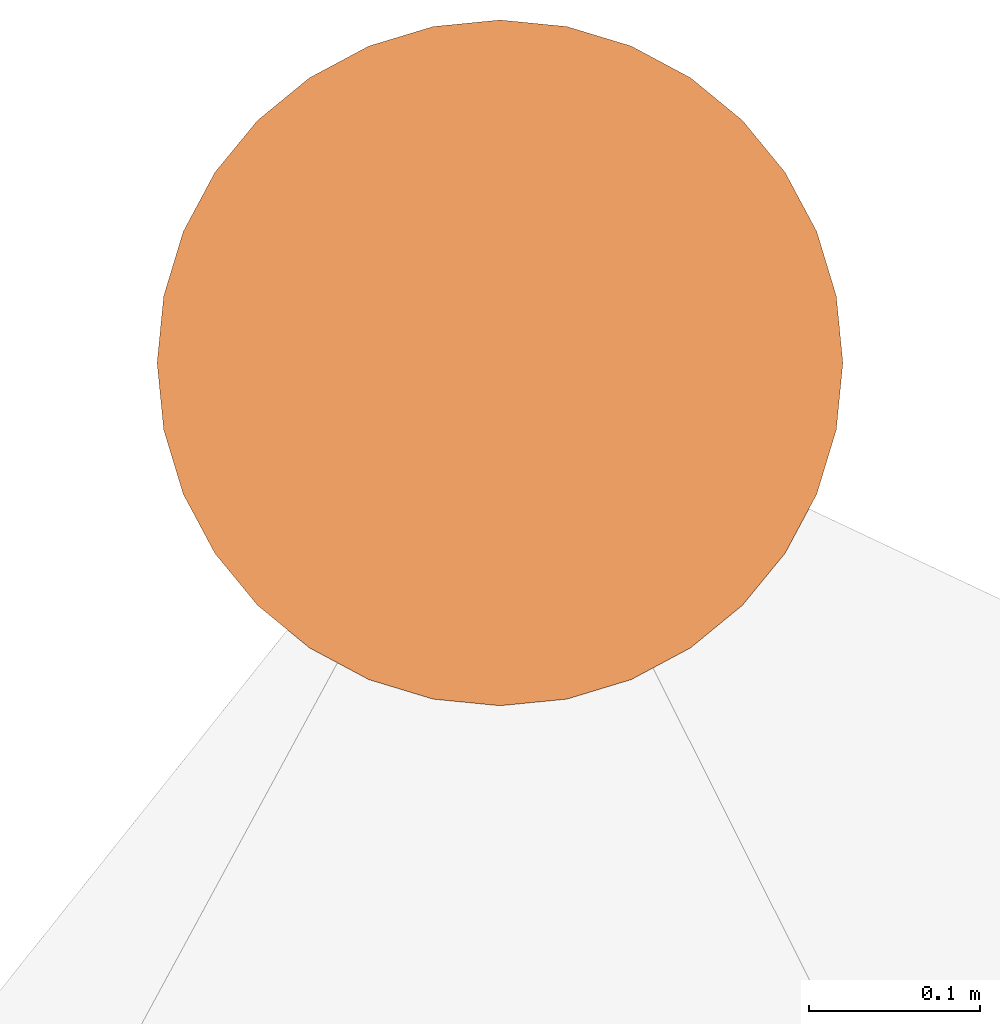
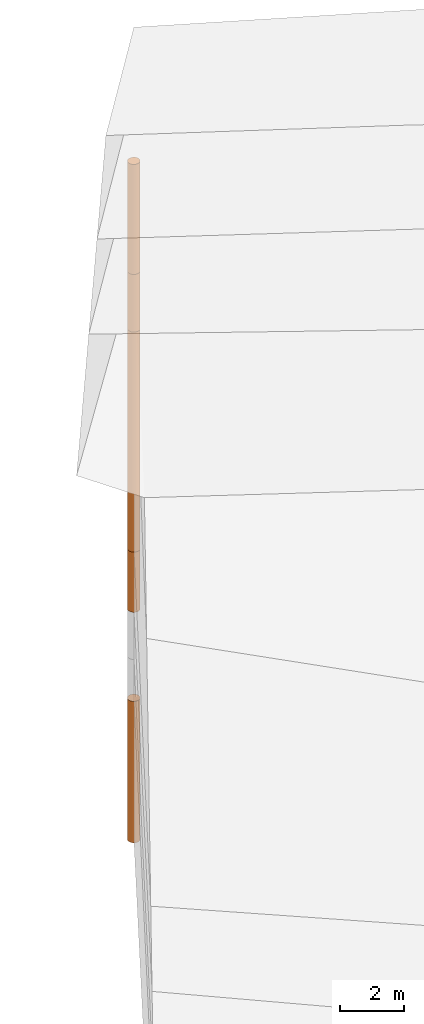
# One storey, part 18 of 24: 5 geographic elements.
"""IFC4 building model written with IfcOpenShell, lengths in metres."""

from ifc_helpers import new_model, entity, si_unit, converted_unit, frame, origin_with_axes, origin_2d_with_axis, place, context, subcontext, project, spatial, polygons, element, save


model = new_model("IFC4")

# Units and contexts
model_context = context("Model", 3, precision=1e-05, world=origin_with_axes())
plan_context = context("Plan", 2, precision=1e-05, world=origin_2d_with_axis())
body_context = subcontext(model_context, "Body", "Model", "MODEL_VIEW")
ifc_project = project(units=[converted_unit("PLANEANGLEUNIT", "degree", entity("IfcReal", 0.0174532925199433), si_unit("PLANEANGLEUNIT", "RADIAN"), dimensions=[0, 0, 0, 0, 0, 0, 0]), si_unit("AREAUNIT", "SQUARE_METRE"), si_unit("VOLUMEUNIT", "CUBIC_METRE"), si_unit("LENGTHUNIT", "METRE")], contexts=[model_context, plan_context])

# Site, building, storey
site_placement = place(None, origin_with_axes())
site = spatial("IfcSite", under=ifc_project, at=site_placement)
building_placement = place(site_placement, origin_with_axes())
building = spatial("IfcBuilding", under=site, at=building_placement, Name="Building")
storey_placement = place(building_placement, origin_with_axes())
storey = spatial("IfcBuildingStorey", under=building, at=storey_placement, Name="Storey")

# Geographic elements
geographic_element_1_placement = place(storey_placement, frame((19.3999996185303, 90.9000015258789, -2.14999771118164), z_axis=(0.0, 0.0, 1.0), x_axis=(1.0, 0.0, 0.0)))
element("IfcGeographicElement", 1, at=geographic_element_1_placement, inside=storey, PredefinedType="NOTDEFINED", context=body_context, shape_type="Tessellation", body=[
    polygons([(0.0, 0.0, -1.14999973773956), (0.0390180610120296, 0.196157038211823, -1.14999973773956), (0.0, 0.199999988079071, -1.14999973773956), (0.0, 0.0, 1.14999973773956), (0.0, 0.199999988079071, 1.14999973773956), (0.0390180610120296, 0.196157038211823, 1.14999973773956), (0.0765366926789284, 0.18477588891983, -1.14999973773956), (0.0765366926789284, 0.18477588891983, 1.14999973773956), (0.111114047467709, 0.166293919086456, -1.14999973773956), (0.111114047467709, 0.166293919086456, 1.14999973773956), (0.141421362757683, 0.141421362757683, -1.14999973773956), (0.141421362757683, 0.141421362757683, 1.14999973773956), (0.166293919086456, 0.111114047467709, -1.14999973773956), (0.166293919086456, 0.111114047467709, 1.14999973773956), (0.18477588891983, 0.0765366926789284, -1.14999973773956), (0.18477588891983, 0.0765366926789284, 1.14999973773956), (0.196157038211823, 0.0390180610120296, -1.14999973773956), (0.196157038211823, 0.0390180610120296, 1.14999973773956), (0.199999988079071, 0.0, -1.14999973773956), (0.199999988079071, 0.0, 1.14999973773956), (0.196157038211823, -0.0390180610120296, -1.14999973773956), (0.196157038211823, -0.0390180610120296, 1.14999973773956), (0.18477588891983, -0.0765366926789284, -1.14999973773956), (0.18477588891983, -0.0765366926789284, 1.14999973773956), (0.166293919086456, -0.111114047467709, -1.14999973773956), (0.166293919086456, -0.111114047467709, 1.14999973773956), (0.141421362757683, -0.141421362757683, -1.14999973773956), (0.141421362757683, -0.141421362757683, 1.14999973773956), (0.111114047467709, -0.166293919086456, -1.14999973773956), (0.111114047467709, -0.166293919086456, 1.14999973773956), (0.0765366926789284, -0.18477588891983, -1.14999973773956), (0.0765366926789284, -0.18477588891983, 1.14999973773956), (0.0390180610120296, -0.196157038211823, -1.14999973773956), (0.0390180610120296, -0.196157038211823, 1.14999973773956), (0.0, -0.199999988079071, -1.14999973773956), (0.0, -0.199999988079071, 1.14999973773956), (-0.0390180610120296, -0.196157038211823, -1.14999973773956), (-0.0390180610120296, -0.196157038211823, 1.14999973773956), (-0.0765366926789284, -0.18477588891983, -1.14999973773956), (-0.0765366926789284, -0.18477588891983, 1.14999973773956), (-0.111114047467709, -0.166293919086456, -1.14999973773956), (-0.111114047467709, -0.166293919086456, 1.14999973773956), (-0.141421362757683, -0.141421362757683, -1.14999973773956), (-0.141421362757683, -0.141421362757683, 1.14999973773956), (-0.166293919086456, -0.111114047467709, -1.14999973773956), (-0.166293919086456, -0.111114047467709, 1.14999973773956), (-0.18477588891983, -0.0765366926789284, -1.14999973773956), (-0.18477588891983, -0.0765366926789284, 1.14999973773956), (-0.196157038211823, -0.0390180610120296, -1.14999973773956), (-0.196157038211823, -0.0390180610120296, 1.14999973773956), (-0.199999988079071, 0.0, -1.14999973773956), (-0.199999988079071, 0.0, 1.14999973773956), (-0.196157038211823, 0.0390180610120296, -1.14999973773956), (-0.196157038211823, 0.0390180610120296, 1.14999973773956), (-0.18477588891983, 0.0765366926789284, -1.14999973773956), (-0.18477588891983, 0.0765366926789284, 1.14999973773956), (-0.166293919086456, 0.111114047467709, -1.14999973773956), (-0.166293919086456, 0.111114047467709, 1.14999973773956), (-0.141421362757683, 0.141421362757683, -1.14999973773956), (-0.141421362757683, 0.141421362757683, 1.14999973773956), (-0.111114047467709, 0.166293919086456, -1.14999973773956), (-0.111114047467709, 0.166293919086456, 1.14999973773956), (-0.0765366926789284, 0.18477588891983, -1.14999973773956), (-0.0765366926789284, 0.18477588891983, 1.14999973773956), (-0.0390180610120296, 0.196157038211823, -1.14999973773956), (-0.0390180610120296, 0.196157038211823, 1.14999973773956)], [[[3, 2, 1]], [[6, 5, 4]], [[28, 30, 29, 27]], [[2, 7, 1]], [[8, 6, 4]], [[42, 44, 43, 41]], [[7, 9, 1]], [[10, 8, 4]], [[10, 12, 11, 9]], [[9, 11, 1]], [[12, 10, 4]], [[11, 13, 1]], [[12, 4, 14]], [[46, 48, 47, 45]], [[1, 13, 15]], [[14, 4, 16]], [[34, 36, 35, 33]], [[1, 15, 17]], [[16, 4, 18]], [[54, 56, 55, 53]], [[1, 17, 19]], [[4, 20, 18]], [[16, 18, 17, 15]], [[1, 19, 21]], [[4, 22, 20]], [[18, 20, 19, 17]], [[1, 21, 23]], [[22, 4, 24]], [[20, 22, 21, 19]], [[1, 23, 25]], [[24, 4, 26]], [[58, 60, 59, 57]], [[1, 25, 27]], [[26, 4, 28]], [[24, 26, 25, 23]], [[1, 27, 29]], [[28, 4, 30]], [[26, 28, 27, 25]], [[1, 29, 31]], [[4, 32, 30]], [[5, 6, 2, 3]], [[1, 31, 33]], [[4, 34, 32]], [[64, 66, 65, 63]], [[1, 33, 35]], [[4, 36, 34]], [[8, 10, 9, 7]], [[1, 35, 37]], [[4, 38, 36]], [[32, 34, 33, 31]], [[1, 37, 39]], [[4, 40, 38]], [[36, 38, 37, 35]], [[1, 39, 41]], [[4, 42, 40]], [[38, 40, 39, 37]], [[43, 1, 41]], [[4, 44, 42]], [[40, 42, 41, 39]], [[45, 1, 43]], [[4, 46, 44]], [[6, 8, 7, 2]], [[47, 1, 45]], [[4, 48, 46]], [[66, 5, 3, 65]], [[49, 1, 47]], [[4, 50, 48]], [[50, 52, 51, 49]], [[49, 51, 1]], [[52, 50, 4]], [[14, 16, 15, 13]], [[51, 53, 1]], [[54, 52, 4]], [[48, 50, 49, 47]], [[55, 1, 53]], [[4, 56, 54]], [[52, 54, 53, 51]], [[57, 1, 55]], [[4, 58, 56]], [[22, 24, 23, 21]], [[59, 1, 57]], [[60, 58, 4]], [[56, 58, 57, 55]], [[59, 61, 1]], [[62, 60, 4]], [[30, 32, 31, 29]], [[61, 63, 1]], [[64, 62, 4]], [[60, 62, 61, 59]], [[63, 65, 1]], [[66, 64, 4]], [[62, 64, 63, 61]], [[65, 3, 1]], [[5, 66, 4]], [[44, 46, 45, 43]], [[12, 14, 13, 11]]]),
])
geographic_element_2_placement = place(storey_placement, frame((19.3999996185303, 90.9000015258789, 3.20000219345093), z_axis=(0.0, 0.0, 1.0), x_axis=(1.0, 0.0, 0.0)))
element("IfcGeographicElement", 2, at=geographic_element_2_placement, inside=storey, PredefinedType="NOTDEFINED", context=body_context, shape_type="Tessellation", body=[
    polygons([(0.0, 0.0, -4.19999933242798), (0.0390180610120296, 0.196157038211823, -4.19999933242798), (0.0, 0.199999988079071, -4.19999933242798), (0.0, 0.0, 4.19999933242798), (0.0, 0.199999988079071, 4.19999933242798), (0.0390180610120296, 0.196157038211823, 4.19999933242798), (0.0765366926789284, 0.18477588891983, -4.19999933242798), (0.0765366926789284, 0.18477588891983, 4.19999933242798), (0.111114047467709, 0.166293919086456, -4.19999933242798), (0.111114047467709, 0.166293919086456, 4.19999933242798), (0.141421362757683, 0.141421362757683, -4.19999933242798), (0.141421362757683, 0.141421362757683, 4.19999933242798), (0.166293919086456, 0.111114047467709, -4.19999933242798), (0.166293919086456, 0.111114047467709, 4.19999933242798), (0.18477588891983, 0.0765366926789284, -4.19999933242798), (0.18477588891983, 0.0765366926789284, 4.19999933242798), (0.196157038211823, 0.0390180610120296, -4.19999933242798), (0.196157038211823, 0.0390180610120296, 4.19999933242798), (0.199999988079071, 0.0, -4.19999933242798), (0.199999988079071, 0.0, 4.19999933242798), (0.196157038211823, -0.0390180610120296, -4.19999933242798), (0.196157038211823, -0.0390180610120296, 4.19999933242798), (0.18477588891983, -0.0765366926789284, -4.19999933242798), (0.18477588891983, -0.0765366926789284, 4.19999933242798), (0.166293919086456, -0.111114047467709, -4.19999933242798), (0.166293919086456, -0.111114047467709, 4.19999933242798), (0.141421362757683, -0.141421362757683, -4.19999933242798), (0.141421362757683, -0.141421362757683, 4.19999933242798), (0.111114047467709, -0.166293919086456, -4.19999933242798), (0.111114047467709, -0.166293919086456, 4.19999933242798), (0.0765366926789284, -0.18477588891983, -4.19999933242798), (0.0765366926789284, -0.18477588891983, 4.19999933242798), (0.0390180610120296, -0.196157038211823, -4.19999933242798), (0.0390180610120296, -0.196157038211823, 4.19999933242798), (0.0, -0.199999988079071, -4.19999933242798), (0.0, -0.199999988079071, 4.19999933242798), (-0.0390180610120296, -0.196157038211823, -4.19999933242798), (-0.0390180610120296, -0.196157038211823, 4.19999933242798), (-0.0765366926789284, -0.18477588891983, -4.19999933242798), (-0.0765366926789284, -0.18477588891983, 4.19999933242798), (-0.111114047467709, -0.166293919086456, -4.19999933242798), (-0.111114047467709, -0.166293919086456, 4.19999933242798), (-0.141421362757683, -0.141421362757683, -4.19999933242798), (-0.141421362757683, -0.141421362757683, 4.19999933242798), (-0.166293919086456, -0.111114047467709, -4.19999933242798), (-0.166293919086456, -0.111114047467709, 4.19999933242798), (-0.18477588891983, -0.0765366926789284, -4.19999933242798), (-0.18477588891983, -0.0765366926789284, 4.19999933242798), (-0.196157038211823, -0.0390180610120296, -4.19999933242798), (-0.196157038211823, -0.0390180610120296, 4.19999933242798), (-0.199999988079071, 0.0, -4.19999933242798), (-0.199999988079071, 0.0, 4.19999933242798), (-0.196157038211823, 0.0390180610120296, -4.19999933242798), (-0.196157038211823, 0.0390180610120296, 4.19999933242798), (-0.18477588891983, 0.0765366926789284, -4.19999933242798), (-0.18477588891983, 0.0765366926789284, 4.19999933242798), (-0.166293919086456, 0.111114047467709, -4.19999933242798), (-0.166293919086456, 0.111114047467709, 4.19999933242798), (-0.141421362757683, 0.141421362757683, -4.19999933242798), (-0.141421362757683, 0.141421362757683, 4.19999933242798), (-0.111114047467709, 0.166293919086456, -4.19999933242798), (-0.111114047467709, 0.166293919086456, 4.19999933242798), (-0.0765366926789284, 0.18477588891983, -4.19999933242798), (-0.0765366926789284, 0.18477588891983, 4.19999933242798), (-0.0390180610120296, 0.196157038211823, -4.19999933242798), (-0.0390180610120296, 0.196157038211823, 4.19999933242798)], [[[3, 2, 1]], [[6, 5, 4]], [[66, 5, 3, 65]], [[2, 7, 1]], [[8, 6, 4]], [[64, 66, 65, 63]], [[7, 9, 1]], [[10, 8, 4]], [[42, 44, 43, 41]], [[9, 11, 1]], [[12, 10, 4]], [[12, 14, 13, 11]], [[1, 11, 13]], [[12, 4, 14]], [[41, 39, 40, 42]], [[1, 13, 15]], [[14, 4, 16]], [[26, 28, 27, 25]], [[1, 15, 17]], [[16, 4, 18]], [[5, 6, 2, 3]], [[1, 17, 19]], [[4, 20, 18]], [[34, 36, 35, 33]], [[1, 19, 21]], [[20, 4, 22]], [[18, 20, 19, 17]], [[1, 21, 23]], [[22, 4, 24]], [[6, 8, 7, 2]], [[1, 23, 25]], [[4, 26, 24]], [[60, 62, 61, 59]], [[1, 25, 27]], [[4, 28, 26]], [[28, 30, 29, 27]], [[1, 27, 29]], [[28, 4, 30]], [[9, 7, 8, 10]], [[1, 29, 31]], [[4, 32, 30]], [[58, 60, 59, 57]], [[1, 31, 33]], [[4, 34, 32]], [[44, 46, 45, 43]], [[1, 33, 35]], [[4, 36, 34]], [[36, 38, 37, 35]], [[1, 35, 37]], [[4, 38, 36]], [[54, 56, 55, 53]], [[1, 37, 39]], [[4, 40, 38]], [[32, 34, 33, 31]], [[1, 39, 41]], [[4, 42, 40]], [[24, 26, 25, 23]], [[43, 1, 41]], [[4, 44, 42]], [[43, 45, 1]], [[4, 46, 44]], [[56, 58, 57, 55]], [[45, 47, 1]], [[4, 48, 46]], [[63, 61, 62, 64]], [[49, 1, 47]], [[4, 50, 48]], [[38, 40, 39, 37]], [[51, 1, 49]], [[52, 50, 4]], [[48, 50, 49, 47]], [[51, 53, 1]], [[4, 54, 52]], [[50, 52, 51, 49]], [[55, 1, 53]], [[4, 56, 54]], [[52, 54, 53, 51]], [[57, 1, 55]], [[58, 56, 4]], [[46, 48, 47, 45]], [[59, 1, 57]], [[60, 58, 4]], [[10, 12, 11, 9]], [[59, 61, 1]], [[62, 60, 4]], [[14, 16, 15, 13]], [[61, 63, 1]], [[64, 62, 4]], [[31, 29, 30, 32]], [[63, 65, 1]], [[66, 64, 4]], [[20, 22, 21, 19]], [[65, 3, 1]], [[5, 66, 4]], [[22, 24, 23, 21]], [[16, 18, 17, 15]]]),
])
geographic_element_3_placement = place(storey_placement, frame((19.3999996185303, 90.9000015258789, 8.50000190734863), z_axis=(0.0, 0.0, 1.0), x_axis=(1.0, 0.0, 0.0)))
element("IfcGeographicElement", 3, at=geographic_element_3_placement, inside=storey, PredefinedType="NOTDEFINED", context=body_context, shape_type="Tessellation", body=[
    polygons([(0.0, 0.0, -1.09999990463257), (0.0390180610120296, 0.196157038211823, -1.09999990463257), (0.0, 0.199999988079071, -1.09999990463257), (0.0, 0.0, 1.09999990463257), (0.0, 0.199999988079071, 1.09999990463257), (0.0390180610120296, 0.196157038211823, 1.09999990463257), (0.0765366926789284, 0.18477588891983, -1.09999990463257), (0.0765366926789284, 0.18477588891983, 1.09999990463257), (0.111114047467709, 0.166293919086456, -1.09999990463257), (0.111114047467709, 0.166293919086456, 1.09999990463257), (0.141421362757683, 0.141421362757683, -1.09999990463257), (0.141421362757683, 0.141421362757683, 1.09999990463257), (0.166293919086456, 0.111114047467709, -1.09999990463257), (0.166293919086456, 0.111114047467709, 1.09999990463257), (0.18477588891983, 0.0765366926789284, -1.09999990463257), (0.18477588891983, 0.0765366926789284, 1.09999990463257), (0.196157038211823, 0.0390180610120296, -1.09999990463257), (0.196157038211823, 0.0390180610120296, 1.09999990463257), (0.199999988079071, 0.0, -1.09999990463257), (0.199999988079071, 0.0, 1.09999990463257), (0.196157038211823, -0.0390180610120296, -1.09999990463257), (0.196157038211823, -0.0390180610120296, 1.09999990463257), (0.18477588891983, -0.0765366926789284, -1.09999990463257), (0.18477588891983, -0.0765366926789284, 1.09999990463257), (0.166293919086456, -0.111114047467709, -1.09999990463257), (0.166293919086456, -0.111114047467709, 1.09999990463257), (0.141421362757683, -0.141421362757683, -1.09999990463257), (0.141421362757683, -0.141421362757683, 1.09999990463257), (0.111114047467709, -0.166293919086456, -1.09999990463257), (0.111114047467709, -0.166293919086456, 1.09999990463257), (0.0765366926789284, -0.18477588891983, -1.09999990463257), (0.0765366926789284, -0.18477588891983, 1.09999990463257), (0.0390180610120296, -0.196157038211823, -1.09999990463257), (0.0390180610120296, -0.196157038211823, 1.09999990463257), (0.0, -0.199999988079071, -1.09999990463257), (0.0, -0.199999988079071, 1.09999990463257), (-0.0390180610120296, -0.196157038211823, -1.09999990463257), (-0.0390180610120296, -0.196157038211823, 1.09999990463257), (-0.0765366926789284, -0.18477588891983, -1.09999990463257), (-0.0765366926789284, -0.18477588891983, 1.09999990463257), (-0.111114047467709, -0.166293919086456, -1.09999990463257), (-0.111114047467709, -0.166293919086456, 1.09999990463257), (-0.141421362757683, -0.141421362757683, -1.09999990463257), (-0.141421362757683, -0.141421362757683, 1.09999990463257), (-0.166293919086456, -0.111114047467709, -1.09999990463257), (-0.166293919086456, -0.111114047467709, 1.09999990463257), (-0.18477588891983, -0.0765366926789284, -1.09999990463257), (-0.18477588891983, -0.0765366926789284, 1.09999990463257), (-0.196157038211823, -0.0390180610120296, -1.09999990463257), (-0.196157038211823, -0.0390180610120296, 1.09999990463257), (-0.199999988079071, 0.0, -1.09999990463257), (-0.199999988079071, 0.0, 1.09999990463257), (-0.196157038211823, 0.0390180610120296, -1.09999990463257), (-0.196157038211823, 0.0390180610120296, 1.09999990463257), (-0.18477588891983, 0.0765366926789284, -1.09999990463257), (-0.18477588891983, 0.0765366926789284, 1.09999990463257), (-0.166293919086456, 0.111114047467709, -1.09999990463257), (-0.166293919086456, 0.111114047467709, 1.09999990463257), (-0.141421362757683, 0.141421362757683, -1.09999990463257), (-0.141421362757683, 0.141421362757683, 1.09999990463257), (-0.111114047467709, 0.166293919086456, -1.09999990463257), (-0.111114047467709, 0.166293919086456, 1.09999990463257), (-0.0765366926789284, 0.18477588891983, -1.09999990463257), (-0.0765366926789284, 0.18477588891983, 1.09999990463257), (-0.0390180610120296, 0.196157038211823, -1.09999990463257), (-0.0390180610120296, 0.196157038211823, 1.09999990463257)], [[[3, 2, 1]], [[6, 5, 4]], [[28, 30, 29, 27]], [[2, 7, 1]], [[8, 6, 4]], [[42, 44, 43, 41]], [[7, 9, 1]], [[10, 8, 4]], [[10, 12, 11, 9]], [[9, 11, 1]], [[12, 10, 4]], [[11, 13, 1]], [[12, 4, 14]], [[46, 48, 47, 45]], [[1, 13, 15]], [[4, 16, 14]], [[34, 36, 35, 33]], [[1, 15, 17]], [[4, 18, 16]], [[54, 56, 55, 53]], [[1, 17, 19]], [[4, 20, 18]], [[16, 18, 17, 15]], [[1, 19, 21]], [[20, 4, 22]], [[18, 20, 19, 17]], [[1, 21, 23]], [[22, 4, 24]], [[20, 22, 21, 19]], [[1, 23, 25]], [[4, 26, 24]], [[58, 60, 59, 57]], [[1, 25, 27]], [[26, 4, 28]], [[24, 26, 25, 23]], [[1, 27, 29]], [[28, 4, 30]], [[26, 28, 27, 25]], [[1, 29, 31]], [[4, 32, 30]], [[5, 6, 2, 3]], [[1, 31, 33]], [[4, 34, 32]], [[64, 66, 65, 63]], [[1, 33, 35]], [[4, 36, 34]], [[8, 10, 9, 7]], [[1, 35, 37]], [[4, 38, 36]], [[32, 34, 33, 31]], [[1, 37, 39]], [[4, 40, 38]], [[36, 38, 37, 35]], [[1, 39, 41]], [[4, 42, 40]], [[38, 40, 39, 37]], [[43, 1, 41]], [[4, 44, 42]], [[40, 42, 41, 39]], [[45, 1, 43]], [[4, 46, 44]], [[6, 8, 7, 2]], [[45, 47, 1]], [[48, 46, 4]], [[66, 5, 3, 65]], [[49, 1, 47]], [[50, 48, 4]], [[50, 52, 51, 49]], [[51, 1, 49]], [[52, 50, 4]], [[14, 16, 15, 13]], [[51, 53, 1]], [[4, 54, 52]], [[48, 50, 49, 47]], [[53, 55, 1]], [[4, 56, 54]], [[52, 54, 53, 51]], [[55, 57, 1]], [[58, 56, 4]], [[22, 24, 23, 21]], [[59, 1, 57]], [[60, 58, 4]], [[56, 58, 57, 55]], [[59, 61, 1]], [[62, 60, 4]], [[30, 32, 31, 29]], [[61, 63, 1]], [[64, 62, 4]], [[60, 62, 61, 59]], [[63, 65, 1]], [[66, 64, 4]], [[62, 64, 63, 61]], [[65, 3, 1]], [[5, 66, 4]], [[44, 46, 45, 43]], [[12, 14, 13, 11]]]),
])
geographic_element_4_placement = place(storey_placement, frame((19.3999996185303, 90.9000015258789, 11.7000017166138), z_axis=(0.0, 0.0, 1.0), x_axis=(1.0, 0.0, 0.0)))
element("IfcGeographicElement", 4, at=geographic_element_4_placement, inside=storey, PredefinedType="NOTDEFINED", context=body_context, shape_type="Tessellation", body=[
    polygons([(0.0, 0.0, -2.09999966621399), (0.0390180610120296, 0.196157038211823, -2.09999966621399), (0.0, 0.199999988079071, -2.09999966621399), (0.0, 0.0, 2.09999966621399), (0.0, 0.199999988079071, 2.09999966621399), (0.0390180610120296, 0.196157038211823, 2.09999966621399), (0.0765366926789284, 0.18477588891983, -2.09999966621399), (0.0765366926789284, 0.18477588891983, 2.09999966621399), (0.111114047467709, 0.166293919086456, -2.09999966621399), (0.111114047467709, 0.166293919086456, 2.09999966621399), (0.141421362757683, 0.141421362757683, -2.09999966621399), (0.141421362757683, 0.141421362757683, 2.09999966621399), (0.166293919086456, 0.111114047467709, -2.09999966621399), (0.166293919086456, 0.111114047467709, 2.09999966621399), (0.18477588891983, 0.0765366926789284, -2.09999966621399), (0.18477588891983, 0.0765366926789284, 2.09999966621399), (0.196157038211823, 0.0390180610120296, -2.09999966621399), (0.196157038211823, 0.0390180610120296, 2.09999966621399), (0.199999988079071, 0.0, -2.09999966621399), (0.199999988079071, 0.0, 2.09999966621399), (0.196157038211823, -0.0390180610120296, -2.09999966621399), (0.196157038211823, -0.0390180610120296, 2.09999966621399), (0.18477588891983, -0.0765366926789284, -2.09999966621399), (0.18477588891983, -0.0765366926789284, 2.09999966621399), (0.166293919086456, -0.111114047467709, -2.09999966621399), (0.166293919086456, -0.111114047467709, 2.09999966621399), (0.141421362757683, -0.141421362757683, -2.09999966621399), (0.141421362757683, -0.141421362757683, 2.09999966621399), (0.111114047467709, -0.166293919086456, -2.09999966621399), (0.111114047467709, -0.166293919086456, 2.09999966621399), (0.0765366926789284, -0.18477588891983, -2.09999966621399), (0.0765366926789284, -0.18477588891983, 2.09999966621399), (0.0390180610120296, -0.196157038211823, -2.09999966621399), (0.0390180610120296, -0.196157038211823, 2.09999966621399), (0.0, -0.199999988079071, -2.09999966621399), (0.0, -0.199999988079071, 2.09999966621399), (-0.0390180610120296, -0.196157038211823, -2.09999966621399), (-0.0390180610120296, -0.196157038211823, 2.09999966621399), (-0.0765366926789284, -0.18477588891983, -2.09999966621399), (-0.0765366926789284, -0.18477588891983, 2.09999966621399), (-0.111114047467709, -0.166293919086456, -2.09999966621399), (-0.111114047467709, -0.166293919086456, 2.09999966621399), (-0.141421362757683, -0.141421362757683, -2.09999966621399), (-0.141421362757683, -0.141421362757683, 2.09999966621399), (-0.166293919086456, -0.111114047467709, -2.09999966621399), (-0.166293919086456, -0.111114047467709, 2.09999966621399), (-0.18477588891983, -0.0765366926789284, -2.09999966621399), (-0.18477588891983, -0.0765366926789284, 2.09999966621399), (-0.196157038211823, -0.0390180610120296, -2.09999966621399), (-0.196157038211823, -0.0390180610120296, 2.09999966621399), (-0.199999988079071, 0.0, -2.09999966621399), (-0.199999988079071, 0.0, 2.09999966621399), (-0.196157038211823, 0.0390180610120296, -2.09999966621399), (-0.196157038211823, 0.0390180610120296, 2.09999966621399), (-0.18477588891983, 0.0765366926789284, -2.09999966621399), (-0.18477588891983, 0.0765366926789284, 2.09999966621399), (-0.166293919086456, 0.111114047467709, -2.09999966621399), (-0.166293919086456, 0.111114047467709, 2.09999966621399), (-0.141421362757683, 0.141421362757683, -2.09999966621399), (-0.141421362757683, 0.141421362757683, 2.09999966621399), (-0.111114047467709, 0.166293919086456, -2.09999966621399), (-0.111114047467709, 0.166293919086456, 2.09999966621399), (-0.0765366926789284, 0.18477588891983, -2.09999966621399), (-0.0765366926789284, 0.18477588891983, 2.09999966621399), (-0.0390180610120296, 0.196157038211823, -2.09999966621399), (-0.0390180610120296, 0.196157038211823, 2.09999966621399)], [[[3, 2, 1]], [[6, 5, 4]], [[34, 36, 35, 33]], [[2, 7, 1]], [[8, 6, 4]], [[36, 38, 37, 35]], [[7, 9, 1]], [[10, 8, 4]], [[56, 58, 57, 55]], [[9, 11, 1]], [[12, 10, 4]], [[58, 60, 59, 57]], [[11, 13, 1]], [[12, 4, 14]], [[8, 10, 9, 7]], [[1, 13, 15]], [[4, 16, 14]], [[10, 12, 11, 9]], [[1, 15, 17]], [[16, 4, 18]], [[18, 20, 19, 17]], [[1, 17, 19]], [[4, 20, 18]], [[20, 22, 21, 19]], [[1, 19, 21]], [[20, 4, 22]], [[22, 24, 23, 21]], [[1, 21, 23]], [[22, 4, 24]], [[38, 40, 39, 37]], [[1, 23, 25]], [[24, 4, 26]], [[40, 42, 41, 39]], [[1, 25, 27]], [[26, 4, 28]], [[24, 26, 25, 23]], [[1, 27, 29]], [[28, 4, 30]], [[62, 64, 63, 61]], [[1, 29, 31]], [[4, 32, 30]], [[28, 30, 29, 27]], [[1, 31, 33]], [[4, 34, 32]], [[5, 6, 2, 3]], [[1, 33, 35]], [[4, 36, 34]], [[30, 32, 31, 29]], [[1, 35, 37]], [[4, 38, 36]], [[32, 34, 33, 31]], [[1, 37, 39]], [[4, 40, 38]], [[6, 8, 7, 2]], [[1, 39, 41]], [[4, 42, 40]], [[42, 44, 43, 41]], [[43, 1, 41]], [[4, 44, 42]], [[44, 46, 45, 43]], [[45, 1, 43]], [[4, 46, 44]], [[46, 48, 47, 45]], [[47, 1, 45]], [[48, 46, 4]], [[60, 62, 61, 59]], [[49, 1, 47]], [[4, 50, 48]], [[16, 18, 17, 15]], [[51, 1, 49]], [[52, 50, 4]], [[48, 50, 49, 47]], [[51, 53, 1]], [[4, 54, 52]], [[66, 5, 3, 65]], [[55, 1, 53]], [[4, 56, 54]], [[52, 54, 53, 51]], [[55, 57, 1]], [[4, 58, 56]], [[59, 1, 57]], [[60, 58, 4]], [[12, 14, 13, 11]], [[59, 61, 1]], [[62, 60, 4]], [[14, 16, 15, 13]], [[61, 63, 1]], [[64, 62, 4]], [[26, 28, 27, 25]], [[63, 65, 1]], [[66, 64, 4]], [[54, 56, 55, 53]], [[65, 3, 1]], [[5, 66, 4]], [[50, 52, 51, 49]], [[64, 66, 65, 63]]]),
])
geographic_element_5_placement = place(storey_placement, frame((19.3999996185303, 90.9000015258789, -9.39999675750732), z_axis=(0.0, 0.0, 1.0), x_axis=(1.0, 0.0, 0.0)))
element("IfcGeographicElement", 5, at=geographic_element_5_placement, inside=storey, PredefinedType="NOTDEFINED", context=body_context, shape_type="Tessellation", body=[
    polygons([(0.0, 0.0, -2.69999980926514), (0.0390180610120296, 0.196157038211823, -2.69999980926514), (0.0, 0.199999988079071, -2.69999980926514), (0.0, 0.0, 2.69999980926514), (0.0, 0.199999988079071, 2.69999980926514), (0.0390180610120296, 0.196157038211823, 2.69999980926514), (0.0765366926789284, 0.18477588891983, -2.69999980926514), (0.0765366926789284, 0.18477588891983, 2.69999980926514), (0.111114047467709, 0.166293919086456, -2.69999980926514), (0.111114047467709, 0.166293919086456, 2.69999980926514), (0.141421362757683, 0.141421362757683, -2.69999980926514), (0.141421362757683, 0.141421362757683, 2.69999980926514), (0.166293919086456, 0.111114047467709, -2.69999980926514), (0.166293919086456, 0.111114047467709, 2.69999980926514), (0.18477588891983, 0.0765366926789284, -2.69999980926514), (0.18477588891983, 0.0765366926789284, 2.69999980926514), (0.196157038211823, 0.0390180610120296, -2.69999980926514), (0.196157038211823, 0.0390180610120296, 2.69999980926514), (0.199999988079071, 0.0, -2.69999980926514), (0.199999988079071, 0.0, 2.69999980926514), (0.196157038211823, -0.0390180610120296, -2.69999980926514), (0.196157038211823, -0.0390180610120296, 2.69999980926514), (0.18477588891983, -0.0765366926789284, -2.69999980926514), (0.18477588891983, -0.0765366926789284, 2.69999980926514), (0.166293919086456, -0.111114047467709, -2.69999980926514), (0.166293919086456, -0.111114047467709, 2.69999980926514), (0.141421362757683, -0.141421362757683, -2.69999980926514), (0.141421362757683, -0.141421362757683, 2.69999980926514), (0.111114047467709, -0.166293919086456, -2.69999980926514), (0.111114047467709, -0.166293919086456, 2.69999980926514), (0.0765366926789284, -0.18477588891983, -2.69999980926514), (0.0765366926789284, -0.18477588891983, 2.69999980926514), (0.0390180610120296, -0.196157038211823, -2.69999980926514), (0.0390180610120296, -0.196157038211823, 2.69999980926514), (0.0, -0.199999988079071, -2.69999980926514), (0.0, -0.199999988079071, 2.69999980926514), (-0.0390180610120296, -0.196157038211823, -2.69999980926514), (-0.0390180610120296, -0.196157038211823, 2.69999980926514), (-0.0765366926789284, -0.18477588891983, -2.69999980926514), (-0.0765366926789284, -0.18477588891983, 2.69999980926514), (-0.111114047467709, -0.166293919086456, -2.69999980926514), (-0.111114047467709, -0.166293919086456, 2.69999980926514), (-0.141421362757683, -0.141421362757683, -2.69999980926514), (-0.141421362757683, -0.141421362757683, 2.69999980926514), (-0.166293919086456, -0.111114047467709, -2.69999980926514), (-0.166293919086456, -0.111114047467709, 2.69999980926514), (-0.18477588891983, -0.0765366926789284, -2.69999980926514), (-0.18477588891983, -0.0765366926789284, 2.69999980926514), (-0.196157038211823, -0.0390180610120296, -2.69999980926514), (-0.196157038211823, -0.0390180610120296, 2.69999980926514), (-0.199999988079071, 0.0, -2.69999980926514), (-0.199999988079071, 0.0, 2.69999980926514), (-0.196157038211823, 0.0390180610120296, -2.69999980926514), (-0.196157038211823, 0.0390180610120296, 2.69999980926514), (-0.18477588891983, 0.0765366926789284, -2.69999980926514), (-0.18477588891983, 0.0765366926789284, 2.69999980926514), (-0.166293919086456, 0.111114047467709, -2.69999980926514), (-0.166293919086456, 0.111114047467709, 2.69999980926514), (-0.141421362757683, 0.141421362757683, -2.69999980926514), (-0.141421362757683, 0.141421362757683, 2.69999980926514), (-0.111114047467709, 0.166293919086456, -2.69999980926514), (-0.111114047467709, 0.166293919086456, 2.69999980926514), (-0.0765366926789284, 0.18477588891983, -2.69999980926514), (-0.0765366926789284, 0.18477588891983, 2.69999980926514), (-0.0390180610120296, 0.196157038211823, -2.69999980926514), (-0.0390180610120296, 0.196157038211823, 2.69999980926514)], [[[3, 2, 1]], [[6, 5, 4]], [[28, 30, 29, 27]], [[2, 7, 1]], [[8, 6, 4]], [[64, 66, 65, 63]], [[7, 9, 1]], [[10, 8, 4]], [[9, 11, 1]], [[12, 10, 4]], [[6, 8, 7, 2]], [[1, 11, 13]], [[12, 4, 14]], [[66, 5, 3, 65]], [[1, 13, 15]], [[4, 16, 14]], [[12, 14, 13, 11]], [[1, 15, 17]], [[4, 18, 16]], [[14, 16, 15, 13]], [[1, 17, 19]], [[4, 20, 18]], [[16, 18, 17, 15]], [[1, 19, 21]], [[20, 4, 22]], [[18, 20, 19, 17]], [[1, 21, 23]], [[4, 24, 22]], [[20, 22, 21, 19]], [[1, 23, 25]], [[4, 26, 24]], [[22, 24, 23, 21]], [[27, 1, 25]], [[4, 28, 26]], [[24, 26, 25, 23]], [[1, 27, 29]], [[28, 4, 30]], [[26, 28, 27, 25]], [[1, 29, 31]], [[4, 32, 30]], [[5, 6, 2, 3]], [[1, 31, 33]], [[4, 34, 32]], [[30, 32, 31, 29]], [[1, 33, 35]], [[4, 36, 34]], [[8, 10, 9, 7]], [[1, 35, 37]], [[4, 38, 36]], [[32, 34, 33, 31]], [[1, 37, 39]], [[4, 40, 38]], [[36, 38, 37, 35]], [[1, 39, 41]], [[4, 42, 40]], [[38, 40, 39, 37]], [[43, 1, 41]], [[4, 44, 42]], [[40, 42, 41, 39]], [[43, 45, 1]], [[46, 44, 4]], [[42, 44, 43, 41]], [[45, 47, 1]], [[48, 46, 4]], [[44, 46, 45, 43]], [[47, 49, 1]], [[50, 48, 4]], [[46, 48, 47, 45]], [[51, 1, 49]], [[52, 50, 4]], [[48, 50, 49, 47]], [[51, 53, 1]], [[4, 54, 52]], [[50, 52, 51, 49]], [[53, 55, 1]], [[56, 54, 4]], [[52, 54, 53, 51]], [[55, 57, 1]], [[58, 56, 4]], [[54, 56, 55, 53]], [[57, 59, 1]], [[60, 58, 4]], [[56, 58, 57, 55]], [[59, 61, 1]], [[62, 60, 4]], [[58, 60, 59, 57]], [[61, 63, 1]], [[64, 62, 4]], [[60, 62, 61, 59]], [[63, 65, 1]], [[66, 64, 4]], [[62, 64, 63, 61]], [[65, 3, 1]], [[5, 66, 4]], [[34, 36, 35, 33]], [[10, 12, 11, 9]]]),
])

save(model, "model.ifc")
